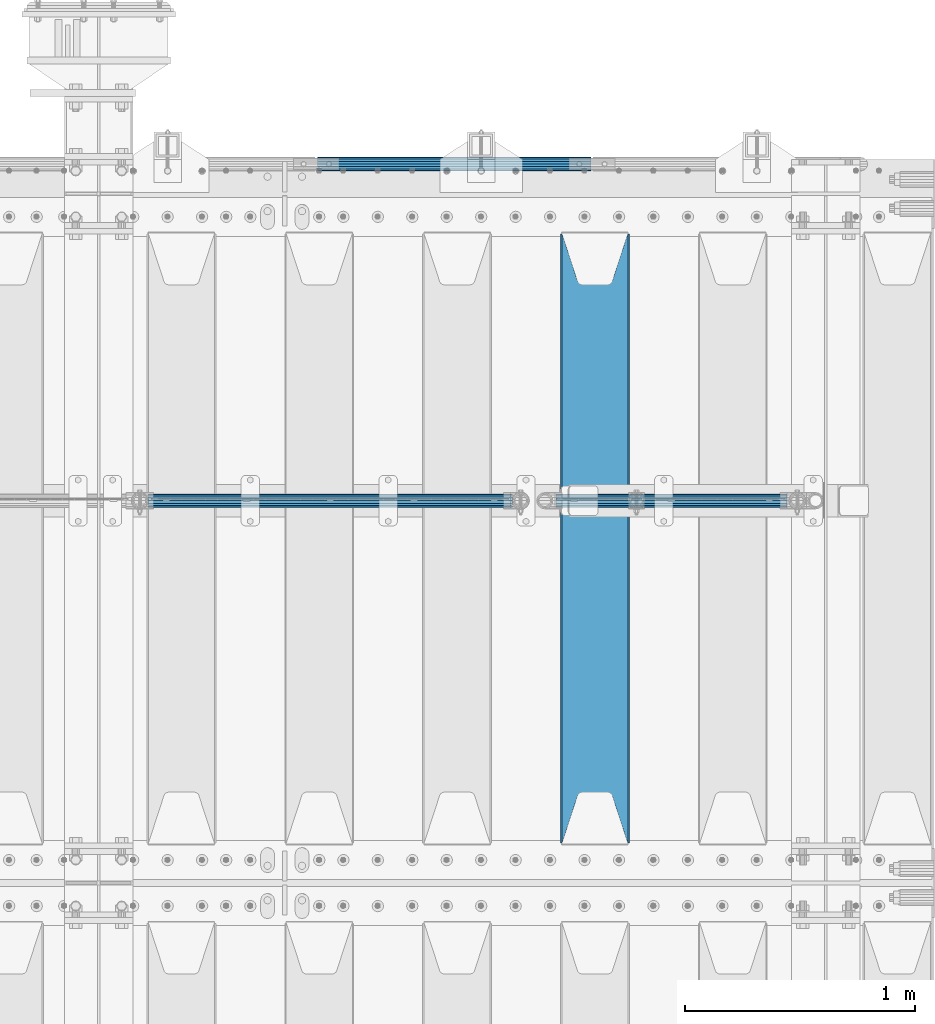
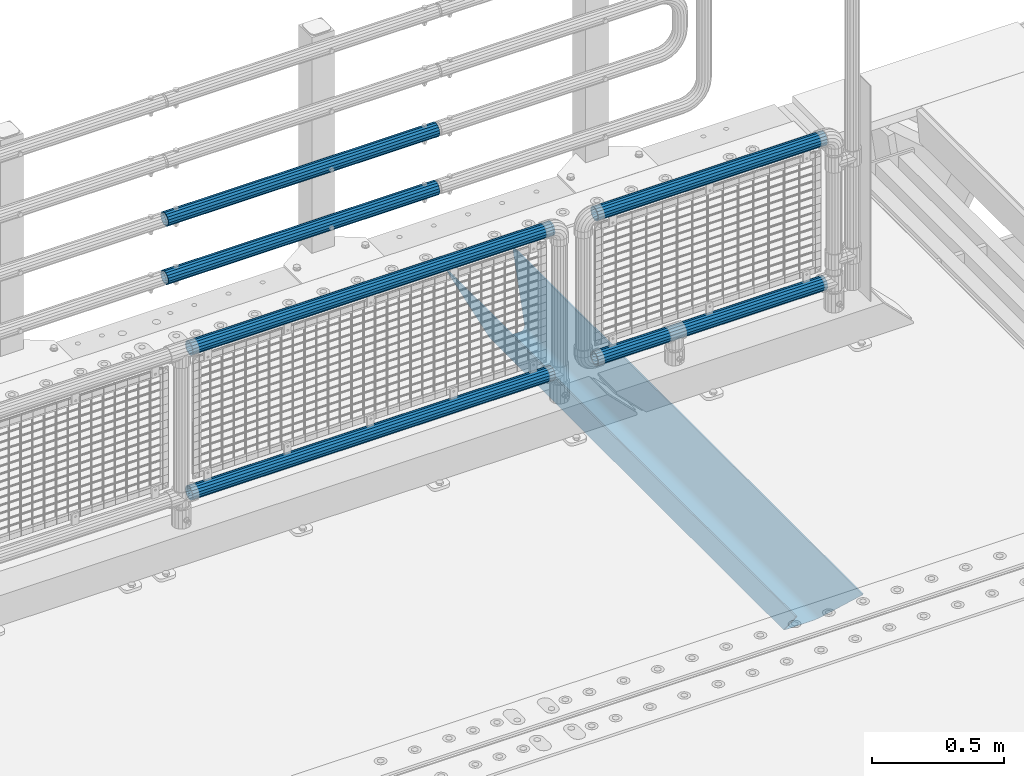
# One storey, part 117 of 219: 7 beams.
"""IFC2X3 building model written with IfcOpenShell, lengths in millimetres."""

from ifc_helpers import new_model, si_unit, frame, origin_with_axes, place, context, subcontext, project, spatial, faceted_brep, material, type_object, element, save


model = new_model("IFC2X3")

# Units and contexts
model_context = context("Model", 3, precision=1e-05, world=origin_with_axes())
body_context = subcontext(model_context, "Body", "Model", "MODEL_VIEW")
ifc_project = project(units=[si_unit("LENGTHUNIT", "METRE", prefix="MILLI"), si_unit("AREAUNIT", "SQUARE_METRE"), si_unit("VOLUMEUNIT", "CUBIC_METRE"), si_unit("MASSUNIT", "GRAM", prefix="KILO"), si_unit("TIMEUNIT", "SECOND"), si_unit("PLANEANGLEUNIT", "RADIAN"), si_unit("SOLIDANGLEUNIT", "STERADIAN"), si_unit("THERMODYNAMICTEMPERATUREUNIT", "DEGREE_CELSIUS"), si_unit("LUMINOUSINTENSITYUNIT", "LUMEN")], contexts=[model_context])

# Site, building, storey
site_placement = place(None, origin_with_axes())
site = spatial("IfcSite", under=ifc_project, at=site_placement, CompositionType="ELEMENT")
building_placement = place(site_placement, origin_with_axes())
building = spatial("IfcBuilding", under=site, at=building_placement, Name="Standard", CompositionType="ELEMENT")
storey_placement = place(building_placement, origin_with_axes())
storey = spatial("IfcBuildingStorey", under=building, at=storey_placement, Name="Undefined", CompositionType="ELEMENT", Elevation=0.0)

# Beams
ifc_material_1 = material(Name="STEEL/S355N")
beam_type_1 = type_object("IfcBeamType", PredefinedType="NOTDEFINED")
beam_1_placement = place(storey_placement, frame((12550.0, 30175.0, -115.0), z_axis=(0.0, 0.0, 1.0), x_axis=(0.0, 1.0, 0.0)))
element("IfcBeam", 1, at=beam_1_placement, inside=storey, type_object=beam_type_1, material=ifc_material_1, context=body_context, shape_type="Brep", body=[
    faceted_brep([(0.0, 150.0, 115.0), (0.0, 143.690000000001, 115.0), (2650.00000000297, 143.690000000001, 115.0), (2650.00000000297, 150.0, 115.0), (2650.00000000297, 142.0595652184, 110.000000003094), (2650.00000000297, 148.3695652184, 110.000000003094), (2441.90079219209, -80.110360073113, -98.0992078077845), (2437.7588105432, -77.5672621345566, -102.241189456673), (2434.06523489747, -74.4080125315541, -105.934765102404), (2430.9108609509, -70.7102721255742, -109.089139048974), (2428.37322971128, -66.5649389910068, -111.626770288588), (2426.51472138055, -62.0739139532889, -113.485278619323), (2425.38102192092, -57.3475956567672, -114.618978078955), (2424.99999999988, -52.5021667386536, -115.0), (2424.99999999988, 52.5021667386536, -115.0), (2425.38102192092, 57.3475956567672, -114.618978078955), (2426.51472138055, 62.0739139532889, -113.485278619323), (2428.37322971128, 66.5649389910068, -111.626770288588), (2430.9108609509, 70.7102721255742, -109.089139048974), (2434.06523489747, 74.4080125315541, -105.934765102404), (2437.7588105432, 77.5672621345566, -102.241189456673), (2441.90079219209, 80.110360073113, -98.0992078077846), (2446.38936140512, 81.9747917625791, -93.6106385947584), (2448.2494850041, 76.2713538057269, -91.7505149957729), (2444.62967112263, 74.7677798626082, -95.3703288772456), (2441.28936334127, 72.7168944282894, -98.710636658607), (2438.31067330439, 70.1691124903828, -101.689326695487), (2435.76682334748, 67.1870637758839, -104.233176652398), (2433.72034654134, 63.8440531834913, -106.279653458539), (2432.22154950042, 60.2222587982342, -107.778450499454), (2431.30727574265, 56.4107117849107, -108.692724257221), (2430.99999999987, 52.5031078186894, -109.0), (2430.99999999987, -52.5031078186894, -109.0), (2431.30727574265, -56.4107117849107, -108.692724257221), (2432.22154950042, -60.2222587982342, -107.778450499454), (2433.72034654134, -63.8440531834913, -106.279653458539), (2435.76682334748, -67.1870637758839, -104.233176652398), (2438.31067330439, -70.1691124903828, -101.689326695487), (2441.28936334127, -72.7168944282894, -98.7106366586071), (2444.62967112263, -74.7677798626082, -95.3703288772457), (2448.2494850041, -76.2713538057269, -91.7505149957729), (2650.00000000297, -142.0595652184, 110.000000003094), (2650.00000000297, -148.3695652184, 110.000000003094), (2446.38936140512, -81.9747917625791, -93.6106385947584), (2650.00000000297, -143.690000000001, 115.0), (2650.00000000297, -150.0, 115.0), (0.0, -143.690000000001, 115.0), (0.0, -150.0, 115.0), (0.0, -148.369565218261, 110.000000002667), (203.610638597427, -81.9747917625791, -93.6106385947584), (208.09920781045, -80.110360073113, -98.0992078077845), (212.241189459342, -77.5672621345566, -102.241189456673), (215.93476510507, -74.4080125315541, -105.934765102404), (219.089139051641, -70.7102721255742, -109.089139048974), (221.626770291256, -66.5649389910068, -111.626770288588), (223.485278621989, -62.0739139532889, -113.485278619323), (224.618978081624, -57.3475956567672, -114.618978078955), (225.000000002663, -52.5021667386536, -115.0), (225.000000002663, 52.5021667386536, -115.0), (224.618978081624, 57.3475956567672, -114.618978078955), (223.485278621989, 62.0739139532889, -113.485278619323), (221.626770291256, 66.5649389910068, -111.626770288588), (219.089139051641, 70.7102721255742, -109.089139048974), (215.93476510507, 74.4080125315541, -105.934765102404), (212.241189459342, 77.5672621345566, -102.241189456673), (208.09920781045, 80.110360073113, -98.0992078077846), (203.610638597427, 81.9747917625791, -93.6106385947584), (0.0, 148.369565218261, 110.000000002667), (0.0, 142.059565218262, 110.000000002667), (201.750514998439, 76.2713538057269, -91.7505149957729), (205.370328879915, 74.7677798626082, -95.3703288772456), (208.710636661275, 72.7168944282894, -98.710636658607), (211.689326698157, 70.1691124903828, -101.689326695487), (214.233176655063, 67.1870637758839, -104.233176652398), (216.279653461206, 63.8440531834913, -106.279653458539), (217.778450502123, 60.2222587982342, -107.778450499454), (218.69272425989, 56.4107117849107, -108.692724257221), (219.00000000267, 52.5031078186894, -109.0), (219.00000000267, -52.5031078186894, -109.0), (218.69272425989, -56.4107117849107, -108.692724257221), (217.778450502123, -60.2222587982342, -107.778450499454), (216.279653461206, -63.8440531834913, -106.279653458539), (214.233176655063, -67.1870637758839, -104.233176652398), (211.689326698157, -70.1691124903828, -101.689326695487), (208.710636661275, -72.7168944282894, -98.7106366586071), (205.370328879915, -74.7677798626082, -95.3703288772457), (201.750514998439, -76.2713538057269, -91.7505149957729), (0.0, -142.059565218262, 110.000000002667)], [[[0, 1, 2, 3]], [[3, 2, 4, 5]], [[6, 7, 8, 9, 10, 11, 12, 13, 14, 15, 16, 17, 18, 19, 20, 21, 22, 5, 4, 23, 24, 25, 26, 27, 28, 29, 30, 31, 32, 33, 34, 35, 36, 37, 38, 39, 40, 41, 42, 43]], [[44, 45, 42, 41]], [[46, 47, 45, 44]], [[43, 42, 45, 47, 48, 49]], [[6, 43, 49, 50]], [[7, 6, 50, 51]], [[8, 7, 51, 52]], [[9, 8, 52, 53]], [[10, 9, 53, 54]], [[11, 10, 54, 55]], [[12, 11, 55, 56]], [[13, 12, 56, 57]], [[14, 13, 57, 58]], [[15, 14, 58, 59]], [[16, 15, 59, 60]], [[17, 16, 60, 61]], [[18, 17, 61, 62]], [[19, 18, 62, 63]], [[20, 19, 63, 64]], [[21, 20, 64, 65]], [[22, 21, 65, 66]], [[0, 3, 5, 22, 66, 67]], [[1, 0, 67, 68]], [[23, 4, 2, 1, 68, 69]], [[24, 23, 69, 70]], [[25, 24, 70, 71]], [[26, 25, 71, 72]], [[27, 26, 72, 73]], [[28, 27, 73, 74]], [[29, 28, 74, 75]], [[30, 29, 75, 76]], [[31, 30, 76, 77]], [[32, 31, 77, 78]], [[33, 32, 78, 79]], [[34, 33, 79, 80]], [[35, 34, 80, 81]], [[36, 35, 81, 82]], [[37, 36, 82, 83]], [[38, 37, 83, 84]], [[39, 38, 84, 85]], [[40, 39, 85, 86]], [[46, 44, 41, 40, 86, 87]], [[47, 46, 87, 48]], [[86, 85, 84, 83, 82, 81, 80, 79, 78, 77, 76, 75, 74, 73, 72, 71, 70, 69, 68, 67, 66, 65, 64, 63, 62, 61, 60, 59, 58, 57, 56, 55, 54, 53, 52, 51, 50, 49, 48, 87]]]),
])
ifc_material_2 = material()
beam_type_2 = type_object("IfcBeamType", PredefinedType="NOTDEFINED")
beam_2_placement = place(storey_placement, frame((10603.85, 31664.5, 969.850000000001), z_axis=(0.0, 0.0, 1.0), x_axis=(1.0, 0.0, 0.0)))
element("IfcBeam", 2, at=beam_2_placement, inside=storey, type_object=beam_type_2, material=ifc_material_2, context=body_context, shape_type="Brep", body=[
    faceted_brep([(0.0, -25.3499999999985, 0.0), (0.0, -23.4203461491597, 9.70102501045585), (1588.0, -23.4203461491597, 9.70102501045506), (1588.0, -25.3499999999985, 0.0), (0.0, -17.9251569030785, 17.9251569030785), (1588.0, -17.9251569030785, 17.925156903079), (0.0, -9.70102501045403, 23.4203461491616), (1588.0, -9.70102501045403, 23.4203461491611), (0.0, 0.0, 25.3500000000004), (1588.0, 0.0, 25.35), (0.0, 9.70102501045403, 23.4203461491616), (1588.0, 9.70102501045403, 23.4203461491611), (0.0, 17.9251569030785, 17.9251569030785), (1588.0, 17.9251569030785, 17.925156903079), (0.0, 23.4203461491597, 9.70102501045585), (1588.0, 23.4203461491597, 9.70102501045506), (0.0, 25.3499999999985, 0.0), (1588.0, 25.3499999999985, 0.0), (0.0, 23.4203461491597, -9.70102501045585), (1588.0, 23.4203461491597, -9.70102501045506), (0.0, 17.9251569030785, -17.9251569030785), (1588.0, 17.9251569030785, -17.925156903079), (0.0, 9.70102501045403, -23.4203461491616), (1588.0, 9.70102501045403, -23.4203461491611), (0.0, 0.0, -25.3500000000004), (1588.0, 0.0, -25.35), (0.0, -9.70102501045403, -23.4203461491616), (1588.0, -9.70102501045403, -23.4203461491611), (0.0, -17.9251569030785, -17.9251569030785), (1588.0, -17.9251569030785, -17.925156903079), (0.0, -23.4203461491597, -9.70102501045585), (1588.0, -23.4203461491597, -9.70102501045506), (0.0, -30.1500000000015, 0.0), (0.0, -27.8549679052157, -11.5379054858076), (1588.0, -27.8549679052157, -11.5379054858075), (1588.0, -30.1500000000015, 0.0), (0.0, -21.3192694527752, -21.3192694527752), (1588.0, -21.3192694527752, -21.3192694527744), (0.0, -11.5379054858058, -27.8549679052157), (1588.0, -11.5379054858058, -27.8549679052153), (0.0, 0.0, -30.1499999999996), (1588.0, 0.0, -30.15), (0.0, 11.5379054858058, -27.8549679052157), (1588.0, 11.5379054858058, -27.8549679052153), (0.0, 21.3192694527752, -21.3192694527752), (1588.0, 21.3192694527752, -21.3192694527744), (0.0, 27.8549679052157, -11.5379054858076), (1588.0, 27.8549679052157, -11.5379054858074), (0.0, 30.1500000000015, 0.0), (1588.0, 30.1500000000015, 0.0), (0.0, 27.8549679052157, 11.5379054858076), (1588.0, 27.8549679052157, 11.5379054858074), (0.0, 21.3192694527752, 21.3192694527752), (1588.0, 21.3192694527752, 21.3192694527744), (0.0, 11.5379054858058, 27.8549679052157), (1588.0, 11.5379054858058, 27.8549679052153), (0.0, 0.0, 30.1499999999996), (1588.0, 0.0, 30.15), (0.0, -11.5379054858058, 27.8549679052157), (1588.0, -11.5379054858058, 27.8549679052153), (0.0, -21.3192694527752, 21.3192694527752), (1588.0, -21.3192694527752, 21.3192694527744), (0.0, -27.8549679052157, 11.5379054858076), (1588.0, -27.8549679052157, 11.5379054858074)], [[[0, 1, 2, 3]], [[1, 4, 5, 2]], [[4, 6, 7, 5]], [[6, 8, 9, 7]], [[8, 10, 11, 9]], [[10, 12, 13, 11]], [[12, 14, 15, 13]], [[14, 16, 17, 15]], [[16, 18, 19, 17]], [[18, 20, 21, 19]], [[20, 22, 23, 21]], [[22, 24, 25, 23]], [[24, 26, 27, 25]], [[26, 28, 29, 27]], [[28, 30, 31, 29]], [[30, 0, 3, 31]], [[32, 33, 34, 35]], [[33, 36, 37, 34]], [[36, 38, 39, 37]], [[38, 40, 41, 39]], [[40, 42, 43, 41]], [[42, 44, 45, 43]], [[44, 46, 47, 45]], [[46, 48, 49, 47]], [[48, 50, 51, 49]], [[50, 52, 53, 51]], [[52, 54, 55, 53]], [[54, 56, 57, 55]], [[56, 58, 59, 57]], [[58, 60, 61, 59]], [[60, 62, 63, 61]], [[62, 32, 35, 63]], [[37, 39, 41, 43, 45, 47, 49, 51, 53, 55, 57, 59, 61, 63, 35, 34], [5, 7, 9, 11, 13, 15, 17, 19, 21, 23, 25, 27, 29, 31, 3, 2]], [[62, 60, 58, 56, 54, 52, 50, 48, 46, 44, 42, 40, 38, 36, 33, 32], [30, 28, 26, 24, 22, 20, 18, 16, 14, 12, 10, 8, 6, 4, 1, 0]]]),
])
beam_3_placement = place(storey_placement, frame((10603.85, 31664.5, 298.170000000003), z_axis=(0.0, 0.0, 1.0), x_axis=(1.0, 0.0, 0.0)))
element("IfcBeam", 3, at=beam_3_placement, inside=storey, type_object=beam_type_2, material=ifc_material_2, context=body_context, shape_type="Brep", body=[
    faceted_brep([(0.0, -25.3499999999985, 0.0), (0.0, -23.4203461491597, 9.70102501045585), (1588.0, -23.4203461491597, 9.70102501045506), (1588.0, -25.3499999999985, 0.0), (0.0, -17.9251569030785, 17.9251569030785), (1588.0, -17.9251569030785, 17.925156903079), (0.0, -9.70102501045403, 23.4203461491616), (1588.0, -9.70102501045403, 23.4203461491611), (0.0, 0.0, 25.3500000000004), (1588.0, 0.0, 25.35), (0.0, 9.70102501045403, 23.4203461491616), (1588.0, 9.70102501045403, 23.4203461491611), (0.0, 17.9251569030785, 17.9251569030785), (1588.0, 17.9251569030785, 17.925156903079), (0.0, 23.4203461491597, 9.70102501045585), (1588.0, 23.4203461491597, 9.70102501045506), (0.0, 25.3499999999985, 0.0), (1588.0, 25.3499999999985, 0.0), (0.0, 23.4203461491597, -9.70102501045585), (1588.0, 23.4203461491597, -9.70102501045506), (0.0, 17.9251569030785, -17.9251569030785), (1588.0, 17.9251569030785, -17.925156903079), (0.0, 9.70102501045403, -23.4203461491616), (1588.0, 9.70102501045403, -23.4203461491611), (0.0, 0.0, -25.3500000000004), (1588.0, 0.0, -25.35), (0.0, -9.70102501045403, -23.4203461491616), (1588.0, -9.70102501045403, -23.4203461491611), (0.0, -17.9251569030785, -17.9251569030785), (1588.0, -17.9251569030785, -17.925156903079), (0.0, -23.4203461491597, -9.70102501045585), (1588.0, -23.4203461491597, -9.70102501045506), (0.0, -30.1500000000015, 0.0), (0.0, -27.8549679052157, -11.5379054858076), (1588.0, -27.8549679052157, -11.5379054858075), (1588.0, -30.1500000000015, 0.0), (0.0, -21.3192694527752, -21.3192694527752), (1588.0, -21.3192694527752, -21.3192694527744), (0.0, -11.5379054858058, -27.8549679052157), (1588.0, -11.5379054858058, -27.8549679052153), (0.0, 0.0, -30.1499999999996), (1588.0, 0.0, -30.15), (0.0, 11.5379054858058, -27.8549679052157), (1588.0, 11.5379054858058, -27.8549679052153), (0.0, 21.3192694527752, -21.3192694527752), (1588.0, 21.3192694527752, -21.3192694527744), (0.0, 27.8549679052157, -11.5379054858076), (1588.0, 27.8549679052157, -11.5379054858074), (0.0, 30.1500000000015, 0.0), (1588.0, 30.1500000000015, 0.0), (0.0, 27.8549679052157, 11.5379054858076), (1588.0, 27.8549679052157, 11.5379054858074), (0.0, 21.3192694527752, 21.3192694527752), (1588.0, 21.3192694527752, 21.3192694527744), (0.0, 11.5379054858058, 27.8549679052157), (1588.0, 11.5379054858058, 27.8549679052153), (0.0, 0.0, 30.1499999999996), (1588.0, 0.0, 30.15), (0.0, -11.5379054858058, 27.8549679052157), (1588.0, -11.5379054858058, 27.8549679052153), (0.0, -21.3192694527752, 21.3192694527752), (1588.0, -21.3192694527752, 21.3192694527744), (0.0, -27.8549679052157, 11.5379054858076), (1588.0, -27.8549679052157, 11.5379054858074)], [[[0, 1, 2, 3]], [[1, 4, 5, 2]], [[4, 6, 7, 5]], [[6, 8, 9, 7]], [[8, 10, 11, 9]], [[10, 12, 13, 11]], [[12, 14, 15, 13]], [[14, 16, 17, 15]], [[16, 18, 19, 17]], [[18, 20, 21, 19]], [[20, 22, 23, 21]], [[22, 24, 25, 23]], [[24, 26, 27, 25]], [[26, 28, 29, 27]], [[28, 30, 31, 29]], [[30, 0, 3, 31]], [[32, 33, 34, 35]], [[33, 36, 37, 34]], [[36, 38, 39, 37]], [[38, 40, 41, 39]], [[40, 42, 43, 41]], [[42, 44, 45, 43]], [[44, 46, 47, 45]], [[46, 48, 49, 47]], [[48, 50, 51, 49]], [[50, 52, 53, 51]], [[52, 54, 55, 53]], [[54, 56, 57, 55]], [[56, 58, 59, 57]], [[58, 60, 61, 59]], [[60, 62, 63, 61]], [[62, 32, 35, 63]], [[37, 39, 41, 43, 45, 47, 49, 51, 53, 55, 57, 59, 61, 63, 35, 34], [5, 7, 9, 11, 13, 15, 17, 19, 21, 23, 25, 27, 29, 31, 3, 2]], [[62, 60, 58, 56, 54, 52, 50, 48, 46, 44, 42, 40, 38, 36, 33, 32], [30, 28, 26, 24, 22, 20, 18, 16, 14, 12, 10, 8, 6, 4, 1, 0]]]),
])
beam_4_placement = place(storey_placement, frame((12381.6, 31664.5, 298.170000000001), z_axis=(0.0, 0.0, 1.0), x_axis=(1.0, 0.0, 0.0)))
element("IfcBeam", 4, at=beam_4_placement, inside=storey, type_object=beam_type_2, material=ifc_material_2, context=body_context, shape_type="Brep", body=[
    faceted_brep([(0.0, -25.3499999999985, 0.0), (0.0, -23.4203461491597, 9.70102501045585), (1005.0, -23.4203461491597, 9.70102501045506), (1005.0, -25.3499999999985, 0.0), (0.0, -17.9251569030785, 17.9251569030785), (1005.0, -17.9251569030785, 17.925156903079), (0.0, -9.70102501045403, 23.4203461491616), (1005.0, -9.70102501045403, 23.4203461491611), (0.0, 0.0, 25.3500000000004), (1005.0, 0.0, 25.35), (0.0, 9.70102501045403, 23.4203461491616), (1005.0, 9.70102501045403, 23.4203461491611), (0.0, 17.9251569030785, 17.9251569030785), (1005.0, 17.9251569030785, 17.925156903079), (0.0, 23.4203461491597, 9.70102501045585), (1005.0, 23.4203461491597, 9.701025010455), (0.0, 25.3499999999985, 0.0), (1005.0, 25.3499999999985, 0.0), (0.0, 23.4203461491597, -9.70102501045585), (1005.0, 23.4203461491597, -9.70102501045506), (0.0, 17.9251569030785, -17.9251569030785), (1005.0, 17.9251569030785, -17.925156903079), (0.0, 9.70102501045403, -23.4203461491616), (1005.0, 9.70102501045403, -23.4203461491611), (0.0, 0.0, -25.3500000000004), (1005.0, 0.0, -25.35), (0.0, -9.70102501045403, -23.4203461491616), (1005.0, -9.70102501045403, -23.4203461491611), (0.0, -17.9251569030785, -17.9251569030785), (1005.0, -17.9251569030785, -17.925156903079), (0.0, -23.4203461491597, -9.70102501045585), (1005.0, -23.4203461491597, -9.701025010455), (0.0, -30.1500000000015, 0.0), (0.0, -27.8549679052157, -11.5379054858076), (1005.0, -27.8549679052157, -11.5379054858075), (1005.0, -30.1500000000015, 0.0), (0.0, -21.3192694527752, -21.3192694527752), (1005.0, -21.3192694527752, -21.3192694527744), (0.0, -11.5379054858058, -27.8549679052157), (1005.0, -11.5379054858058, -27.8549679052153), (0.0, 0.0, -30.1499999999996), (1005.0, 0.0, -30.15), (0.0, 11.5379054858058, -27.8549679052157), (1005.0, 11.5379054858058, -27.8549679052153), (0.0, 21.3192694527752, -21.3192694527752), (1005.0, 21.3192694527752, -21.3192694527744), (0.0, 27.8549679052157, -11.5379054858076), (1005.0, 27.8549679052157, -11.5379054858075), (0.0, 30.1500000000015, 0.0), (1005.0, 30.1500000000015, 0.0), (0.0, 27.8549679052157, 11.5379054858076), (1005.0, 27.8549679052157, 11.5379054858075), (0.0, 21.3192694527752, 21.3192694527752), (1005.0, 21.3192694527752, 21.3192694527744), (0.0, 11.5379054858058, 27.8549679052157), (1005.0, 11.5379054858058, 27.8549679052153), (0.0, 0.0, 30.1499999999996), (1005.0, 0.0, 30.15), (0.0, -11.5379054858058, 27.8549679052157), (1005.0, -11.5379054858058, 27.8549679052153), (0.0, -21.3192694527752, 21.3192694527752), (1005.0, -21.3192694527752, 21.3192694527744), (0.0, -27.8549679052157, 11.5379054858076), (1005.0, -27.8549679052157, 11.5379054858075)], [[[0, 1, 2, 3]], [[1, 4, 5, 2]], [[4, 6, 7, 5]], [[6, 8, 9, 7]], [[8, 10, 11, 9]], [[10, 12, 13, 11]], [[12, 14, 15, 13]], [[14, 16, 17, 15]], [[16, 18, 19, 17]], [[18, 20, 21, 19]], [[20, 22, 23, 21]], [[22, 24, 25, 23]], [[24, 26, 27, 25]], [[26, 28, 29, 27]], [[28, 30, 31, 29]], [[30, 0, 3, 31]], [[32, 33, 34, 35]], [[33, 36, 37, 34]], [[36, 38, 39, 37]], [[38, 40, 41, 39]], [[40, 42, 43, 41]], [[42, 44, 45, 43]], [[44, 46, 47, 45]], [[46, 48, 49, 47]], [[48, 50, 51, 49]], [[50, 52, 53, 51]], [[52, 54, 55, 53]], [[54, 56, 57, 55]], [[56, 58, 59, 57]], [[58, 60, 61, 59]], [[60, 62, 63, 61]], [[62, 32, 35, 63]], [[37, 39, 41, 43, 45, 47, 49, 51, 53, 55, 57, 59, 61, 63, 35, 34], [5, 7, 9, 11, 13, 15, 17, 19, 21, 23, 25, 27, 29, 31, 3, 2]], [[62, 60, 58, 56, 54, 52, 50, 48, 46, 44, 42, 40, 38, 36, 33, 32], [30, 28, 26, 24, 22, 20, 18, 16, 14, 12, 10, 8, 6, 4, 1, 0]]]),
])
beam_5_placement = place(storey_placement, frame((12381.0, 31664.5, 969.85), z_axis=(0.0, 0.0, 1.0), x_axis=(1.0, 0.0, 0.0)))
element("IfcBeam", 5, at=beam_5_placement, inside=storey, type_object=beam_type_2, material=ifc_material_2, context=body_context, shape_type="Brep", body=[
    faceted_brep([(0.0, -25.3499999999985, 0.0), (0.0, -23.4203461491597, 9.70102501045585), (1005.0, -23.4203461491597, 9.70102501045506), (1005.0, -25.3499999999985, 0.0), (0.0, -17.9251569030785, 17.9251569030785), (1005.0, -17.9251569030785, 17.925156903079), (0.0, -9.70102501045403, 23.4203461491616), (1005.0, -9.70102501045403, 23.4203461491611), (0.0, 0.0, 25.3500000000004), (1005.0, 0.0, 25.35), (0.0, 9.70102501045403, 23.4203461491616), (1005.0, 9.70102501045403, 23.4203461491611), (0.0, 17.9251569030785, 17.9251569030785), (1005.0, 17.9251569030785, 17.925156903079), (0.0, 23.4203461491597, 9.70102501045585), (1005.0, 23.4203461491597, 9.701025010455), (0.0, 25.3499999999985, 0.0), (1005.0, 25.3499999999985, 0.0), (0.0, 23.4203461491597, -9.70102501045585), (1005.0, 23.4203461491597, -9.70102501045506), (0.0, 17.9251569030785, -17.9251569030785), (1005.0, 17.9251569030785, -17.925156903079), (0.0, 9.70102501045403, -23.4203461491616), (1005.0, 9.70102501045403, -23.4203461491611), (0.0, 0.0, -25.3500000000004), (1005.0, 0.0, -25.35), (0.0, -9.70102501045403, -23.4203461491616), (1005.0, -9.70102501045403, -23.4203461491611), (0.0, -17.9251569030785, -17.9251569030785), (1005.0, -17.9251569030785, -17.925156903079), (0.0, -23.4203461491597, -9.70102501045585), (1005.0, -23.4203461491597, -9.701025010455), (0.0, -30.1500000000015, 0.0), (0.0, -27.8549679052157, -11.5379054858076), (1005.0, -27.8549679052157, -11.5379054858075), (1005.0, -30.1500000000015, 0.0), (0.0, -21.3192694527752, -21.3192694527752), (1005.0, -21.3192694527752, -21.3192694527744), (0.0, -11.5379054858058, -27.8549679052157), (1005.0, -11.5379054858058, -27.8549679052153), (0.0, 0.0, -30.1499999999996), (1005.0, 0.0, -30.15), (0.0, 11.5379054858058, -27.8549679052157), (1005.0, 11.5379054858058, -27.8549679052153), (0.0, 21.3192694527752, -21.3192694527752), (1005.0, 21.3192694527752, -21.3192694527744), (0.0, 27.8549679052157, -11.5379054858076), (1005.0, 27.8549679052157, -11.5379054858075), (0.0, 30.1500000000015, 0.0), (1005.0, 30.1500000000015, 0.0), (0.0, 27.8549679052157, 11.5379054858076), (1005.0, 27.8549679052157, 11.5379054858075), (0.0, 21.3192694527752, 21.3192694527752), (1005.0, 21.3192694527752, 21.3192694527744), (0.0, 11.5379054858058, 27.8549679052157), (1005.0, 11.5379054858058, 27.8549679052153), (0.0, 0.0, 30.1499999999996), (1005.0, 0.0, 30.15), (0.0, -11.5379054858058, 27.8549679052157), (1005.0, -11.5379054858058, 27.8549679052153), (0.0, -21.3192694527752, 21.3192694527752), (1005.0, -21.3192694527752, 21.3192694527744), (0.0, -27.8549679052157, 11.5379054858076), (1005.0, -27.8549679052157, 11.5379054858075)], [[[0, 1, 2, 3]], [[1, 4, 5, 2]], [[4, 6, 7, 5]], [[6, 8, 9, 7]], [[8, 10, 11, 9]], [[10, 12, 13, 11]], [[12, 14, 15, 13]], [[14, 16, 17, 15]], [[16, 18, 19, 17]], [[18, 20, 21, 19]], [[20, 22, 23, 21]], [[22, 24, 25, 23]], [[24, 26, 27, 25]], [[26, 28, 29, 27]], [[28, 30, 31, 29]], [[30, 0, 3, 31]], [[32, 33, 34, 35]], [[33, 36, 37, 34]], [[36, 38, 39, 37]], [[38, 40, 41, 39]], [[40, 42, 43, 41]], [[42, 44, 45, 43]], [[44, 46, 47, 45]], [[46, 48, 49, 47]], [[48, 50, 51, 49]], [[50, 52, 53, 51]], [[52, 54, 55, 53]], [[54, 56, 57, 55]], [[56, 58, 59, 57]], [[58, 60, 61, 59]], [[60, 62, 63, 61]], [[62, 32, 35, 63]], [[37, 39, 41, 43, 45, 47, 49, 51, 53, 55, 57, 59, 61, 63, 35, 34], [5, 7, 9, 11, 13, 15, 17, 19, 21, 23, 25, 27, 29, 31, 3, 2]], [[62, 60, 58, 56, 54, 52, 50, 48, 46, 44, 42, 40, 38, 36, 33, 32], [30, 28, 26, 24, 22, 20, 18, 16, 14, 12, 10, 8, 6, 4, 1, 0]]]),
])
beam_type_3 = type_object("IfcBeamType", PredefinedType="NOTDEFINED")
beam_6_placement = place(storey_placement, frame((11342.0000000001, 33129.8499999996, 419.849999999748), z_axis=(0.0, -1.0, 0.0), x_axis=(1.0, 0.0, 0.0)))
element("IfcBeam", 6, at=beam_6_placement, inside=storey, type_object=beam_type_3, material=ifc_material_2, context=body_context, shape_type="Brep", body=[
    faceted_brep([(0.0, -26.5500000000029, 0.0), (0.0, -24.5290015881765, 10.1602451292931), (1190.0, -24.5290015881747, 10.1602451292929), (1190.0, -26.55, 0.0), (0.0, -18.7736850405054, 18.7736850405028), (1190.0, -18.7736850405028, 18.7736850405054), (0.0, -10.1602451292929, 24.5290015881747), (1190.0, -10.1602451292931, 24.5290015881765), (0.0, 0.0, 26.55), (1190.0, 0.0, 26.5500000000029), (0.0, 10.1602451292929, 24.5290015881747), (1190.0, 10.1602451292932, 24.5290015881765), (0.0, 18.7736850405054, 18.7736850405028), (1190.0, 18.7736850405029, 18.7736850405054), (0.0, 24.5290015881765, 10.1602451292931), (1190.0, 24.5290015881747, 10.1602451292929), (0.0, 26.5500000000029, 0.0), (1190.0, 26.55, 0.0), (0.0, 24.5290015881765, -10.1602451292931), (1190.0, 24.5290015881747, -10.1602451292929), (0.0, 18.7736850405054, -18.7736850405028), (1190.0, 18.7736850405028, -18.7736850405054), (0.0, 10.1602451292929, -24.5290015881747), (1190.0, 10.1602451292931, -24.5290015881765), (0.0, 0.0, -26.55), (1190.0, 0.0, -26.5500000000029), (0.0, -10.1602451292929, -24.5290015881747), (1190.0, -10.1602451292931, -24.5290015881765), (0.0, -18.7736850405054, -18.7736850405028), (1190.0, -18.7736850405028, -18.7736850405054), (0.0, -24.5290015881765, -10.1602451292931), (1190.0, -24.5290015881747, -10.1602451292929), (0.0, -30.1500000000015, 0.0), (0.0, -27.8549679052157, -11.5379054858076), (1190.0, -27.8549679052153, -11.5379054858058), (1190.0, -30.15, 0.0), (0.0, -21.3192694527752, -21.3192694527752), (1190.0, -21.3192694527744, -21.3192694527752), (0.0, -11.5379054858058, -27.8549679052157), (1190.0, -11.5379054858075, -27.8549679052157), (0.0, 0.0, -30.1499999999996), (1190.0, 0.0, -30.1500000000015), (0.0, 11.5379054858058, -27.8549679052157), (1190.0, 11.5379054858075, -27.8549679052157), (0.0, 21.3192694527752, -21.3192694527752), (1190.0, 21.3192694527744, -21.3192694527752), (0.0, 27.8549679052157, -11.5379054858076), (1190.0, 27.8549679052153, -11.5379054858058), (0.0, 30.1500000000015, 0.0), (1190.0, 30.15, 0.0), (0.0, 27.8549679052157, 11.5379054858076), (1190.0, 27.8549679052153, 11.5379054858058), (0.0, 21.3192694527752, 21.3192694527752), (1190.0, 21.3192694527744, 21.3192694527752), (0.0, 11.5379054858058, 27.8549679052157), (1190.0, 11.5379054858075, 27.8549679052157), (0.0, 0.0, 30.1499999999996), (1190.0, 0.0, 30.1500000000015), (0.0, -11.5379054858058, 27.8549679052157), (1190.0, -11.5379054858075, 27.8549679052157), (0.0, -21.3192694527752, 21.3192694527752), (1190.0, -21.3192694527744, 21.3192694527752), (0.0, -27.8549679052157, 11.5379054858076), (1190.0, -27.8549679052153, 11.5379054858058)], [[[0, 1, 2, 3]], [[1, 4, 5, 2]], [[4, 6, 7, 5]], [[6, 8, 9, 7]], [[8, 10, 11, 9]], [[10, 12, 13, 11]], [[12, 14, 15, 13]], [[14, 16, 17, 15]], [[16, 18, 19, 17]], [[18, 20, 21, 19]], [[20, 22, 23, 21]], [[22, 24, 25, 23]], [[24, 26, 27, 25]], [[26, 28, 29, 27]], [[28, 30, 31, 29]], [[30, 0, 3, 31]], [[32, 33, 34, 35]], [[33, 36, 37, 34]], [[36, 38, 39, 37]], [[38, 40, 41, 39]], [[40, 42, 43, 41]], [[42, 44, 45, 43]], [[44, 46, 47, 45]], [[46, 48, 49, 47]], [[48, 50, 51, 49]], [[50, 52, 53, 51]], [[52, 54, 55, 53]], [[54, 56, 57, 55]], [[56, 58, 59, 57]], [[58, 60, 61, 59]], [[60, 62, 63, 61]], [[62, 32, 35, 63]], [[37, 39, 41, 43, 45, 47, 49, 51, 53, 55, 57, 59, 61, 63, 35, 34], [5, 7, 9, 11, 13, 15, 17, 19, 21, 23, 25, 27, 29, 31, 3, 2]], [[62, 60, 58, 56, 54, 52, 50, 48, 46, 44, 42, 40, 38, 36, 33, 32], [30, 28, 26, 24, 22, 20, 18, 16, 14, 12, 10, 8, 6, 4, 1, 0]]]),
])
beam_7_placement = place(storey_placement, frame((11342.0000000001, 33129.8499999996, 149.549999999748), z_axis=(0.0, -1.0, 0.0), x_axis=(1.0, 0.0, 0.0)))
element("IfcBeam", 7, at=beam_7_placement, inside=storey, type_object=beam_type_3, material=ifc_material_2, context=body_context, shape_type="Brep", body=[
    faceted_brep([(0.0, -26.5500000000029, 0.0), (0.0, -24.5290015881765, 10.1602451292931), (1190.0, -24.5290015881747, 10.1602451292929), (1190.0, -26.55, 0.0), (0.0, -18.7736850405054, 18.7736850405028), (1190.0, -18.7736850405028, 18.7736850405054), (0.0, -10.1602451292929, 24.5290015881747), (1190.0, -10.1602451292931, 24.5290015881765), (0.0, 0.0, 26.55), (1190.0, 0.0, 26.5500000000029), (0.0, 10.1602451292929, 24.5290015881747), (1190.0, 10.1602451292932, 24.5290015881765), (0.0, 18.7736850405054, 18.7736850405028), (1190.0, 18.7736850405029, 18.7736850405054), (0.0, 24.5290015881765, 10.1602451292931), (1190.0, 24.5290015881747, 10.1602451292929), (0.0, 26.5500000000029, 0.0), (1190.0, 26.55, 0.0), (0.0, 24.5290015881765, -10.1602451292931), (1190.0, 24.5290015881747, -10.1602451292929), (0.0, 18.7736850405054, -18.7736850405028), (1190.0, 18.7736850405028, -18.7736850405054), (0.0, 10.1602451292929, -24.5290015881747), (1190.0, 10.1602451292931, -24.5290015881765), (0.0, 0.0, -26.55), (1190.0, 0.0, -26.5500000000029), (0.0, -10.1602451292929, -24.5290015881747), (1190.0, -10.1602451292931, -24.5290015881765), (0.0, -18.7736850405054, -18.7736850405028), (1190.0, -18.7736850405028, -18.7736850405054), (0.0, -24.5290015881765, -10.1602451292931), (1190.0, -24.5290015881747, -10.1602451292929), (0.0, -30.1500000000015, 0.0), (0.0, -27.8549679052157, -11.5379054858076), (1190.0, -27.8549679052153, -11.5379054858058), (1190.0, -30.15, 0.0), (0.0, -21.3192694527752, -21.3192694527752), (1190.0, -21.3192694527744, -21.3192694527752), (0.0, -11.5379054858058, -27.8549679052157), (1190.0, -11.5379054858075, -27.8549679052157), (0.0, 0.0, -30.1499999999996), (1190.0, 0.0, -30.1500000000015), (0.0, 11.5379054858058, -27.8549679052157), (1190.0, 11.5379054858075, -27.8549679052157), (0.0, 21.3192694527752, -21.3192694527752), (1190.0, 21.3192694527744, -21.3192694527752), (0.0, 27.8549679052157, -11.5379054858076), (1190.0, 27.8549679052153, -11.5379054858058), (0.0, 30.1500000000015, 0.0), (1190.0, 30.15, 0.0), (0.0, 27.8549679052157, 11.5379054858076), (1190.0, 27.8549679052153, 11.5379054858058), (0.0, 21.3192694527752, 21.3192694527752), (1190.0, 21.3192694527744, 21.3192694527752), (0.0, 11.5379054858058, 27.8549679052157), (1190.0, 11.5379054858075, 27.8549679052157), (0.0, 0.0, 30.1499999999996), (1190.0, 0.0, 30.1500000000015), (0.0, -11.5379054858058, 27.8549679052157), (1190.0, -11.5379054858075, 27.8549679052157), (0.0, -21.3192694527752, 21.3192694527752), (1190.0, -21.3192694527744, 21.3192694527752), (0.0, -27.8549679052157, 11.5379054858076), (1190.0, -27.8549679052153, 11.5379054858058)], [[[0, 1, 2, 3]], [[1, 4, 5, 2]], [[4, 6, 7, 5]], [[6, 8, 9, 7]], [[8, 10, 11, 9]], [[10, 12, 13, 11]], [[12, 14, 15, 13]], [[14, 16, 17, 15]], [[16, 18, 19, 17]], [[18, 20, 21, 19]], [[20, 22, 23, 21]], [[22, 24, 25, 23]], [[24, 26, 27, 25]], [[26, 28, 29, 27]], [[28, 30, 31, 29]], [[30, 0, 3, 31]], [[32, 33, 34, 35]], [[33, 36, 37, 34]], [[36, 38, 39, 37]], [[38, 40, 41, 39]], [[40, 42, 43, 41]], [[42, 44, 45, 43]], [[44, 46, 47, 45]], [[46, 48, 49, 47]], [[48, 50, 51, 49]], [[50, 52, 53, 51]], [[52, 54, 55, 53]], [[54, 56, 57, 55]], [[56, 58, 59, 57]], [[58, 60, 61, 59]], [[60, 62, 63, 61]], [[62, 32, 35, 63]], [[37, 39, 41, 43, 45, 47, 49, 51, 53, 55, 57, 59, 61, 63, 35, 34], [5, 7, 9, 11, 13, 15, 17, 19, 21, 23, 25, 27, 29, 31, 3, 2]], [[62, 60, 58, 56, 54, 52, 50, 48, 46, 44, 42, 40, 38, 36, 33, 32], [30, 28, 26, 24, 22, 20, 18, 16, 14, 12, 10, 8, 6, 4, 1, 0]]]),
])

save(model, "model.ifc")
